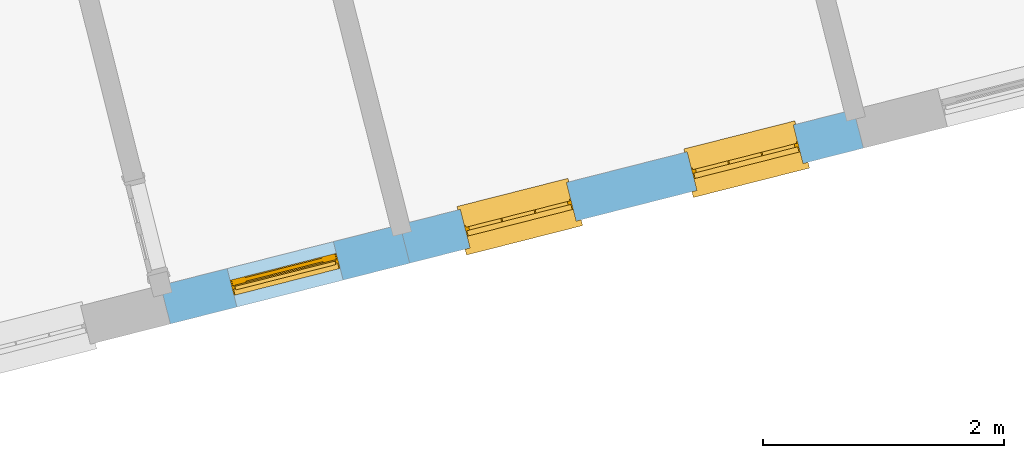
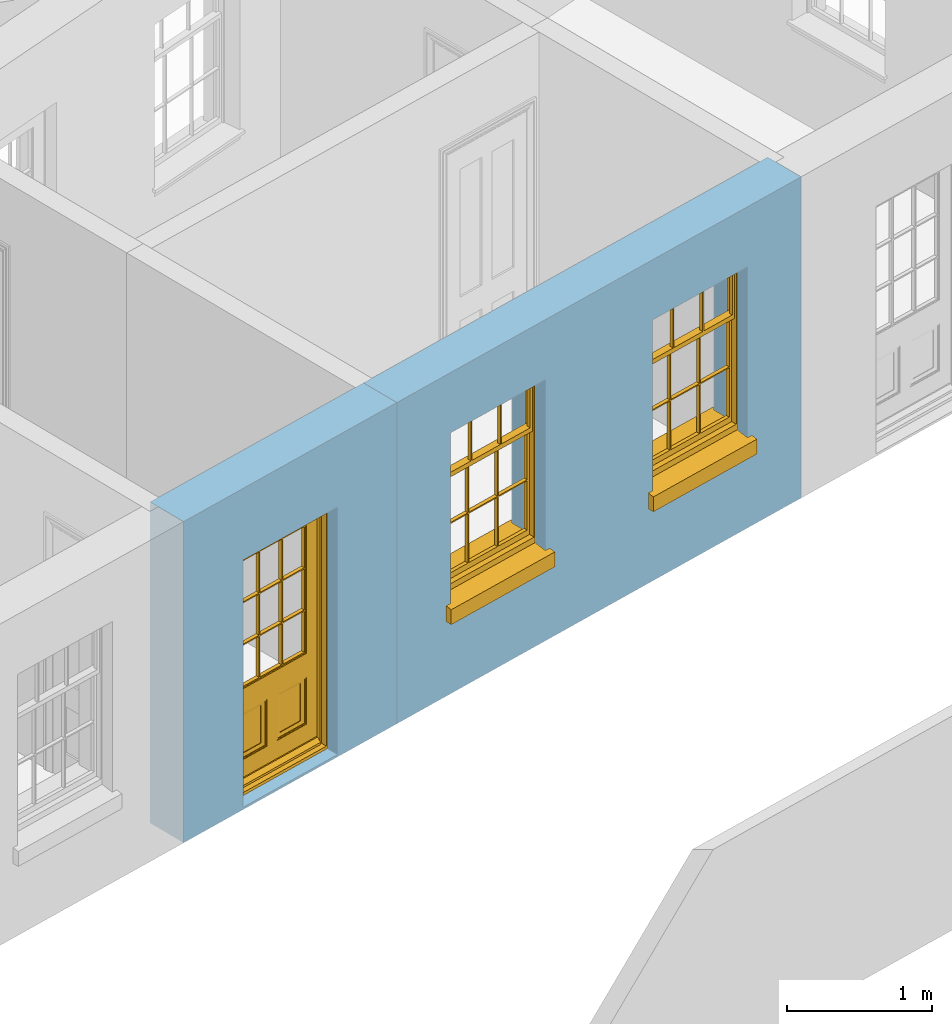
# One storey, part 7 of 15: 2 windows, 1 door, 3 openings, plus 2 elements that do not belong to this part.
"""IFC2X3 building model written with IfcOpenShell, lengths in metres."""

from ifc_helpers import new_model, si_unit, frame, origin, place, context, subcontext, project, spatial, polyline, outline, extrude, faceted_brep, material, layer, layer_set, layer_usage, element, fill, save


model = new_model("IFC2X3")

# Units and contexts
model_context = context("Model", 3, world=origin())
body_context = subcontext(model_context, "Body", "Model", "MODEL_VIEW")
ifc_project = project(units=[si_unit("PLANEANGLEUNIT", "RADIAN"), si_unit("MASSUNIT", "GRAM", prefix="KILO"), si_unit("FORCEUNIT", "NEWTON", prefix="KILO"), si_unit("LENGTHUNIT", "METRE")], contexts=[model_context])

# Site, building, storey
site_placement = place(None, origin())
site = spatial("IfcSite", under=ifc_project, at=site_placement, CompositionType="ELEMENT")
building_placement = place(None, origin())
building = spatial("IfcBuilding", under=site, at=building_placement, Name="Building plot-13", CompositionType="ELEMENT")
storey_placement = place(None, frame((0.0, 0.0, 4.0)))
storey = spatial("IfcBuildingStorey", under=building, at=storey_placement, Name="Floor 0", CompositionType="ELEMENT", Elevation=4.0)

# Wall, opening, door
ifc_material = material(Name="Masonry")
ifc_layer = layer(ifc_material, 0.33, ventilated=False)
ifc_layer_set = layer_set([ifc_layer], Name="My Wall")
ifc_layer_usage = layer_usage(ifc_layer_set, "AXIS2", "NEGATIVE", 0.08)
wall_1_placement = place(storey_placement, origin())
wall_1 = element("IfcWallStandardCase", 1, at=wall_1_placement, inside=storey, material=ifc_layer_usage, Name="exterior", context=body_context, shape_type="SweptSolid", body=[
    extrude(outline(polyline([(71.1697724625834, 45.0137628318924), (71.2509007169492, 44.6938906600119), (73.2374229095042, 45.1977265416814), (73.1562946551384, 45.5175987135619), (71.1697724625834, 45.0137628318924)])), origin(), (0.0, 0.0, 1.0), 2.7),
])
opening_1_placement = place(storey_placement, frame((0.0, 0.0, 0.0199999999999996)))
opening_1 = element("IfcOpeningElement", 2, at=opening_1_placement, cuts=wall_1, Name="Opening", ObjectType="Opening", context=body_context, shape_type="SweptSolid", body=[
    extrude(outline(polyline([(71.8031259398763, 44.8339499470999), (72.6851976865771, 45.0576672545935), (72.6040694322113, 45.377539426474), (71.7219976855105, 45.1538221189804), (71.8031259398763, 44.8339499470999)])), origin(), (0.0, 0.0, 1.0), 2.08),
])
door_placement = place(storey_placement, frame((71.7416651411143, 45.0762773500396, 0.0199999999999996), z_axis=(0.0, 0.0, 1.0), x_axis=(0.882071746700788, 0.223717307493636, 0.0)))
door = element("IfcDoor", 3, at=door_placement, inside=storey, Name="circulation outside door", OverallHeight=2.08, OverallWidth=0.91, context=body_context, shape_type="Brep", held_by="IfcProductRepresentation", body=[
    faceted_brep([(0.545, -0.055, 0.265), (0.745, -0.055, 0.265), (0.745, -0.05, 0.265), (0.545, -0.05, 0.265), (0.745, -0.05, 0.58), (0.545, -0.05, 0.58), (0.545, -0.055, 0.58), (0.515, -0.06, 0.235), (0.775, -0.06, 0.235), (0.745, -0.055, 0.58), (0.515, -0.06, 0.61), (0.515, -0.065, 0.235), (0.775, -0.065, 0.235), (0.775, -0.06, 0.61), (0.515, -0.065, 0.61), (0.785, -0.065, 0.225), (0.505, -0.065, 0.225), (0.775, -0.065, 0.61), (0.505, -0.065, 0.62), (0.785, -0.065, 0.62), (0.505, -0.07, 0.225), (0.785, -0.07, 0.225), (0.505, -0.07, 0.62), (0.785, -0.07, 0.62), (0.883, -0.07, 0.075), (0.898, -0.07, 0.075), (0.405, -0.07, 0.62), (0.405, -0.07, 0.225), (0.027, -0.07, 0.075), (0.785, -0.07, 0.82), (0.125, -0.07, 0.82), (0.405, -0.065, 0.62), (0.405, -0.065, 0.225), (0.898, -0.07, 2.068), (0.027, -0.08, 0.075), (0.883, -0.08, 0.075), (0.125, -0.07, 0.225), (0.012, -0.07, 0.075), (0.785, -0.06, 0.82), (0.125, -0.06, 0.82), (0.125, -0.07, 0.62), (0.125, -0.065, 0.62), (0.395, -0.065, 0.61), (0.395, -0.065, 0.235), (0.125, -0.065, 0.225), (0.785, -0.07, 1.895), (0.027, -0.11, 0.045), (0.883, -0.11, 0.045), (0.558333, -0.06, 0.83), (0.351667, -0.06, 0.83), (0.125, -0.07, 1.895), (0.125, -0.06, 1.895), (0.785, -0.06, 1.895), (0.012, -0.07, 2.068), (0.135, -0.065, 0.61), (0.395, -0.06, 0.61), (0.395, -0.06, 0.235), (0.135, -0.065, 0.235), (0.027, -0.11, 0.027), (0.883, -0.11, 0.027), (0.568333, -0.06, 0.83), (0.558333, -0.03, 0.83), (0.351667, -0.03, 0.83), (0.341667, -0.06, 0.83), (0.135, -0.06, 1.185), (0.135, -0.06, 1.53), (0.775, -0.06, 1.53), (0.775, -0.06, 1.185), (0.135, -0.06, 0.61), (0.365, -0.055, 0.58), (0.365, -0.055, 0.265), (0.135, -0.06, 0.235), (0.568333, -0.06, 1.175), (0.558333, -0.06, 1.175), (0.775, -0.06, 0.83), (0.558333, -0.03, 1.175), (0.785, -0.03, 0.82), (0.125, -0.03, 0.82), (0.351667, -0.03, 1.175), (0.351667, -0.06, 1.175), (0.341667, -0.06, 1.175), (0.135, -0.06, 0.83), (0.135, -0.06, 1.175), (0.135, -0.03, 1.185), (0.135, -0.03, 1.53), (0.135, -0.06, 1.54), (0.351667, -0.06, 1.885), (0.558333, -0.06, 1.885), (0.775, -0.03, 1.53), (0.775, -0.03, 1.185), (0.775, -0.06, 1.175), (0.775, -0.06, 1.54), (0.165, -0.055, 0.58), (0.365, -0.05, 0.58), (0.365, -0.05, 0.265), (0.165, -0.055, 0.265), (0.568333, -0.03, 0.83), (0.568333, -0.03, 1.175), (0.568333, -0.06, 1.185), (0.558333, -0.06, 1.185), (0.775, -0.03, 0.83), (0.785, -0.02, 0.82), (0.125, -0.02, 0.82), (0.341667, -0.03, 0.83), (0.341667, -0.03, 1.175), (0.351667, -0.06, 1.185), (0.341667, -0.06, 1.185), (0.135, -0.03, 0.83), (0.341667, -0.03, 1.185), (0.125, -0.03, 1.895), (0.341667, -0.03, 1.53), (0.341667, -0.06, 1.53), (0.135, -0.06, 1.885), (0.341667, -0.06, 1.54), (0.341667, -0.06, 1.885), (0.558333, -0.03, 1.885), (0.351667, -0.03, 1.885), (0.568333, -0.06, 1.885), (0.785, -0.03, 1.895), (0.568333, -0.03, 1.185), (0.568333, -0.06, 1.53), (0.568333, -0.03, 1.53), (0.568333, -0.06, 1.54), (0.775, -0.06, 1.885), (0.165, -0.05, 0.58), (0.165, -0.05, 0.265), (0.775, -0.03, 1.175), (0.558333, -0.06, 1.53), (0.351667, -0.03, 1.185), (0.558333, -0.03, 1.185), (0.505, -0.02, 0.62), (0.405, -0.02, 0.62), (0.125, -0.02, 1.895), (0.785, -0.02, 1.895), (0.351667, -0.06, 1.53), (0.135, -0.03, 1.175), (0.135, -0.03, 1.54), (0.341667, -0.03, 1.54), (0.135, -0.03, 1.885), (0.351667, -0.06, 1.54), (0.558333, -0.03, 1.54), (0.558333, -0.06, 1.54), (0.351667, -0.03, 1.54), (0.775, -0.03, 1.54), (0.568333, -0.03, 1.54), (0.775, -0.03, 1.885), (0.558333, -0.03, 1.53), (0.405, -0.02, 0.225), (0.505, -0.02, 0.225), (0.125, -0.02, 0.62), (0.785, -0.02, 0.62), (0.012, -0.02, 2.068), (0.898, -0.02, 2.068), (0.351667, -0.03, 1.53), (0.341667, -0.03, 1.885), (0.568333, -0.03, 1.885), (0.405, -0.025, 0.225), (0.405, -0.025, 0.62), (0.505, -0.025, 0.62), (0.505, -0.025, 0.225), (0.898, -0.02, 0.027), (0.012, -0.02, 0.027), (0.125, -0.025, 0.62), (0.785, -0.025, 0.62), (0.395, -0.025, 0.235), (0.395, -0.025, 0.61), (0.125, -0.02, 0.225), (0.125, -0.025, 0.225), (0.515, -0.025, 0.61), (0.515, -0.025, 0.235), (0.785, -0.02, 0.225), (0.785, -0.025, 0.225), (0.135, -0.025, 0.61), (0.775, -0.025, 0.61), (0.135, -0.025, 0.235), (0.395, -0.03, 0.235), (0.395, -0.03, 0.61), (0.515, -0.03, 0.61), (0.515, -0.03, 0.235), (0.775, -0.025, 0.235), (0.135, -0.03, 0.61), (0.775, -0.03, 0.61), (0.135, -0.03, 0.235), (0.365, -0.035, 0.265), (0.365, -0.035, 0.58), (0.545, -0.035, 0.58), (0.545, -0.035, 0.265), (0.775, -0.03, 0.235), (0.165, -0.035, 0.58), (0.745, -0.035, 0.58), (0.165, -0.035, 0.265), (0.365, -0.04, 0.58), (0.365, -0.04, 0.265), (0.545, -0.04, 0.58), (0.545, -0.04, 0.265), (0.745, -0.035, 0.265), (0.165, -0.04, 0.58), (0.745, -0.04, 0.58), (0.165, -0.04, 0.265), (0.745, -0.04, 0.265), (0.885, -0.072, 0.025), (0.025, -0.072, 0.025), (0.025, -0.1, 0.025), (0.885, -0.1, 0.025), (0.9, -0.02, 0.025), (0.01, -0.02, 0.025), (0.9, -0.072, 0.025), (0.91, -0.02, 0.0), (0.0, -0.02, 0.0), (0.01, -0.072, 0.025), (0.9, -0.072, 2.07), (0.9, -0.02, 2.07), (0.885, -0.072, 2.055), (0.91, -0.02, 2.08), (0.01, -0.02, 2.07), (0.0, -0.02, 2.08), (0.01, -0.072, 2.07), (0.025, -0.072, 2.055), (0.0, -0.15, 2.08), (0.91, -0.15, 2.08), (0.01, -0.15, 2.07), (0.9, -0.15, 2.07), (0.01, -0.1, 2.07), (0.9, -0.1, 2.07), (0.0, -0.15, 0.0), (0.91, -0.15, 0.0), (0.01, -0.15, 0.025), (0.9, -0.15, 0.025), (0.01, -0.1, 0.025), (0.025, -0.1, 2.055), (0.9, -0.1, 0.025), (0.885, -0.1, 2.055), (0.898, -0.07, 0.027), (0.012, -0.07, 0.027), (0.883, -0.07, 0.027), (0.027, -0.07, 0.027)], [[[0, 1, 2, 3]], [[2, 4, 5, 3]], [[0, 3, 5, 6]], [[1, 0, 7, 8]], [[9, 4, 2, 1]], [[9, 6, 5, 4]], [[0, 6, 10, 7]], [[8, 7, 11, 12]], [[8, 13, 9, 1]], [[13, 10, 6, 9]], [[7, 10, 14, 11]], [[15, 12, 11, 16]], [[12, 17, 13, 8]], [[17, 14, 10, 13]], [[18, 16, 11, 14]], [[15, 19, 17, 12]], [[15, 16, 20, 21]], [[14, 17, 19, 18]], [[16, 18, 22, 20]], [[21, 23, 19, 15]], [[24, 25, 21, 20]], [[23, 22, 18, 19]], [[20, 22, 26, 27]], [[23, 21, 25]], [[28, 24, 20, 27]], [[22, 23, 29]], [[29, 30, 26, 22]], [[27, 26, 31, 32]], [[23, 25, 33, 29]], [[34, 35, 24, 28]], [[28, 27, 36, 37]], [[38, 39, 30, 29]], [[26, 30, 40]], [[26, 40, 41, 31]], [[42, 43, 32, 31]], [[32, 44, 36, 27]], [[33, 45, 29]], [[46, 47, 35, 34]], [[36, 40, 37]], [[39, 38, 48, 49]], [[50, 30, 39, 51]], [[29, 45, 52, 38]], [[53, 37, 40, 30]], [[44, 41, 40, 36]], [[31, 41, 54, 42]], [[43, 42, 55, 56]], [[57, 44, 32, 43]], [[50, 45, 33, 53]], [[47, 46, 58, 59]], [[60, 48, 38]], [[49, 48, 61, 62]], [[49, 63, 39]], [[50, 53, 30]], [[51, 39, 64, 65]], [[45, 50, 51, 52]], [[66, 67, 38, 52]], [[57, 54, 41, 44]], [[42, 54, 68, 55]], [[56, 55, 69, 70]], [[56, 71, 57, 43]], [[60, 72, 73, 48]], [[60, 38, 74]], [[48, 73, 75, 61]], [[76, 77, 62, 61]], [[62, 78, 79, 49]], [[49, 79, 80, 63]], [[63, 81, 39]], [[82, 64, 39]], [[65, 64, 83, 84]], [[85, 51, 65]], [[52, 51, 86, 87]], [[88, 89, 67, 66]], [[90, 38, 67]], [[91, 66, 52]], [[71, 68, 54, 57]], [[55, 68, 92, 69]], [[69, 93, 94, 70]], [[70, 95, 71, 56]], [[96, 97, 72, 60]], [[73, 72, 98, 99]], [[74, 38, 90]], [[100, 96, 60, 74]], [[75, 73, 79, 78]], [[61, 75, 97, 96]], [[101, 102, 77, 76]], [[77, 103, 62]], [[96, 76, 61]], [[103, 104, 78, 62]], [[80, 79, 105, 106]], [[63, 80, 104, 103]], [[81, 63, 103, 107]], [[81, 82, 39]], [[106, 64, 82, 80]], [[106, 108, 83, 64]], [[84, 83, 77, 109]], [[110, 111, 65, 84]], [[112, 51, 85]], [[113, 85, 65, 111]], [[114, 86, 51]], [[115, 87, 86, 116]], [[117, 52, 87]], [[118, 76, 89, 88]], [[119, 98, 67, 89]], [[120, 121, 88, 66]], [[67, 98, 72, 90]], [[91, 122, 120, 66]], [[91, 52, 123]], [[95, 92, 68, 71]], [[69, 92, 124, 93]], [[94, 93, 124, 125]], [[94, 125, 95, 70]], [[72, 97, 126, 90]], [[127, 99, 98, 120]], [[99, 105, 79, 73]], [[74, 90, 126, 100]], [[96, 100, 76]], [[128, 129, 75, 78]], [[97, 75, 129, 119]], [[130, 131, 102, 101]], [[109, 77, 102, 132]], [[133, 101, 76, 118]], [[77, 107, 103]], [[78, 104, 108, 128]], [[111, 106, 105, 134]], [[104, 80, 82, 135]], [[107, 135, 82, 81]], [[110, 108, 106, 111]], [[104, 135, 83, 108]], [[83, 135, 77]], [[136, 84, 109]], [[110, 84, 136, 137]], [[114, 51, 112]], [[85, 136, 138, 112]], [[113, 137, 136, 85]], [[111, 134, 139, 113]], [[86, 114, 113, 139]], [[140, 141, 87, 115]], [[139, 142, 116, 86]], [[109, 118, 115, 116]], [[117, 123, 52]], [[117, 87, 141, 122]], [[126, 89, 76]], [[143, 118, 88]], [[120, 98, 119, 121]], [[119, 89, 126, 97]], [[144, 143, 88, 121]], [[144, 122, 91, 143]], [[127, 120, 122, 141]], [[143, 91, 123, 145]], [[124, 92, 95, 125]], [[146, 129, 99, 127]], [[99, 129, 128, 105]], [[100, 126, 76]], [[121, 119, 129, 146]], [[147, 131, 130, 148]], [[131, 149, 102]], [[130, 101, 150]], [[102, 151, 132]], [[118, 109, 132, 133]], [[101, 133, 152]], [[107, 77, 135]], [[153, 128, 108, 110]], [[134, 105, 128, 153]], [[109, 138, 136]], [[153, 110, 137, 142]], [[154, 114, 112, 138]], [[137, 113, 114, 154]], [[141, 139, 134, 127]], [[141, 140, 142, 139]], [[144, 140, 115, 155]], [[142, 137, 154, 116]], [[155, 115, 118]], [[116, 154, 109]], [[117, 155, 145, 123]], [[122, 144, 155, 117]], [[143, 145, 118]], [[121, 146, 140, 144]], [[146, 127, 134, 153]], [[156, 157, 131, 147]], [[148, 130, 158, 159]], [[148, 160, 161, 147]], [[157, 162, 149, 131]], [[161, 151, 102, 149]], [[101, 152, 160, 150]], [[163, 158, 130, 150]], [[151, 152, 133, 132]], [[154, 138, 109]], [[142, 140, 146, 153]], [[145, 155, 118]], [[157, 156, 164, 165]], [[147, 166, 167, 156]], [[168, 169, 159, 158]], [[170, 148, 159, 171]], [[148, 170, 160]], [[166, 147, 161]], [[172, 162, 157, 165]], [[166, 149, 162, 167]], [[166, 161, 149]], [[150, 160, 170]], [[163, 173, 168, 158]], [[171, 163, 150, 170]], [[174, 164, 156, 167]], [[175, 176, 165, 164]], [[169, 168, 177, 178]], [[171, 159, 169, 179]], [[167, 162, 172, 174]], [[176, 180, 172, 165]], [[179, 173, 163, 171]], [[181, 177, 168, 173]], [[164, 174, 182, 175]], [[183, 184, 176, 175]], [[178, 177, 185, 186]], [[179, 169, 178, 187]], [[174, 172, 180, 182]], [[184, 188, 180, 176]], [[187, 181, 173, 179]], [[189, 185, 177, 181]], [[175, 182, 190, 183]], [[191, 184, 183, 192]], [[185, 193, 194, 186]], [[187, 178, 186, 195]], [[182, 180, 188, 190]], [[191, 196, 188, 184]], [[195, 189, 181, 187]], [[197, 193, 185, 189]], [[183, 190, 198, 192]], [[198, 196, 191, 192]], [[194, 193, 197, 199]], [[195, 186, 194, 199]], [[188, 196, 198, 190]], [[197, 189, 195, 199]], [[200, 201, 202, 203]], [[201, 200, 204, 205]], [[206, 204, 200]], [[204, 207, 208, 205]], [[209, 201, 205]], [[210, 211, 204, 206]], [[206, 200, 212, 210]], [[211, 213, 207, 204]], [[214, 205, 208, 215]], [[216, 217, 201, 209]], [[205, 214, 216, 209]], [[216, 214, 211, 210]], [[210, 212, 217, 216]], [[214, 215, 213, 211]], [[218, 219, 213, 215]], [[219, 218, 220, 221]], [[221, 220, 222, 223]], [[215, 208, 224, 218]], [[225, 224, 208, 207]], [[224, 226, 220, 218]], [[224, 225, 227, 226]], [[219, 225, 207, 213]], [[228, 222, 220, 226]], [[219, 221, 227, 225]], [[226, 227, 203, 202]], [[202, 229, 222, 228]], [[228, 226, 202]], [[227, 221, 223, 230]], [[230, 203, 227]], [[217, 229, 202, 201]], [[231, 223, 222, 229]], [[230, 223, 231, 203]], [[231, 229, 217, 212]], [[212, 200, 203, 231]], [[33, 152, 151, 53]], [[25, 160, 152, 33]], [[161, 37, 53, 151]], [[232, 160, 25]], [[161, 233, 37]], [[160, 232, 234]], [[24, 234, 232, 25]], [[233, 161, 235]], [[37, 233, 235, 28]], [[161, 160, 234, 235]], [[35, 47, 234, 24]], [[28, 235, 46, 34]], [[58, 235, 234, 59]], [[59, 234, 47]], [[58, 46, 235]]]),
])
fill(opening_1, door)

# Wall, openings, windows
wall_2_placement = place(storey_placement, origin())
wall_2 = element("IfcWallStandardCase", 4, at=wall_2_placement, inside=storey, material=ifc_layer_usage, Name="exterior", context=body_context, shape_type="SweptSolid", body=[
    extrude(outline(polyline([(73.1562946551384, 45.5175987135619), (73.2374229095042, 45.1977265416814), (77.0032448604169, 46.1528410780099), (76.9221166060511, 46.4727132498904), (73.1562946551384, 45.5175987135619)])), origin(), (0.0, 0.0, 1.0), 2.7),
])
opening_2_placement = place(storey_placement, frame((0.0, 0.0, 0.75)))
opening_2 = element("IfcOpeningElement", 5, at=opening_2_placement, cuts=wall_2, Name="Opening", ObjectType="Opening", context=body_context, shape_type="SweptSolid", body=[
    extrude(outline(polyline([(73.737842523882, 45.3246465220167), (74.6199142705828, 45.5483638295104), (74.5387860162169, 45.8682360013909), (73.6567142695161, 45.6445186938972), (73.737842523882, 45.3246465220167)])), origin(), (0.0, 0.0, 1.0), 1.445),
])
opening_3_placement = place(storey_placement, frame((0.0, 0.0, 0.75)))
opening_3 = element("IfcOpeningElement", 6, at=opening_3_placement, cuts=wall_2, Name="Opening", ObjectType="Opening", context=body_context, shape_type="SweptSolid", body=[
    extrude(outline(polyline([(75.6207534993383, 45.802203790181), (76.5028252460391, 46.0259210976746), (76.4216969916733, 46.3457932695551), (75.5396252449725, 46.1220759620615), (75.6207534993383, 45.802203790181)])), origin(), (0.0, 0.0, 1.0), 1.445),
])
window_1_placement = place(storey_placement, frame((73.67638172512, 45.5669739249565, 0.75), z_axis=(0.0, 0.0, 1.0), x_axis=(0.882071746700802, 0.223717307493629, 0.0)))
window_1 = element("IfcWindow", 7, at=window_1_placement, inside=storey, Name="toilet outside window", OverallHeight=1.445, OverallWidth=0.91, context=body_context, shape_type="Brep", held_by="IfcProductRepresentation", body=[
    faceted_brep([(0.876875, -0.105, 0.999097), (0.876875, -0.105, 1.411875), (0.9, -0.105, 1.435), (0.033125, -0.105, 1.411875), (0.033125, -0.105, 0.999097), (0.01, -0.105, 1.435), (0.033125, -0.135, 1.411875), (0.01, -0.135, 1.435), (0.033125, -0.135, 0.999097), (0.876875, -0.135, 1.411875), (0.876875, -0.135, 0.999097), (0.9, -0.135, 1.435), (0.033125, -0.105, 0.960972), (0.01, -0.105, 0.960972), (0.033125, -0.105, 0.548195), (0.876875, -0.105, 0.960972), (0.876875, -0.105, 0.548195), (0.9, -0.105, 0.960972), (0.876875, -0.105, 0.538195), (0.876875, -0.105, 0.125417), (0.9, -0.105, 0.077167), (0.033125, -0.105, 0.125417), (0.033125, -0.105, 0.538195), (0.01, -0.105, 0.077167), (0.9, -0.135, 0.960972), (0.01, -0.135, 0.960972), (-0.0425, -0.25, 0.01), (-0.0425, -0.3, 0.001667), (0.0, -0.25, 0.01), (0.9525, -0.25, 0.01), (0.91, -0.25, 0.01), (0.9525, -0.3, 0.001667), (-0.02, 0.08, 0.077167), (0.0, 0.08, 0.077167), (-0.02, 0.11, 0.077167), (0.0, -0.06, 0.077167), (0.01, -0.06, 0.077167), (0.91, -0.06, 0.077167), (0.91, 0.08, 0.077167), (0.9, -0.06, 0.077167), (0.93, 0.08, 0.077167), (0.93, 0.11, 0.077167), (0.01, -0.105, 0.999097), (0.01, -0.075, 0.999097), (0.9, -0.105, 0.999097), (0.9, -0.075, 0.999097), (0.876875, -0.075, 0.125417), (0.876875, -0.075, 0.538195), (0.9, -0.075, 0.077167), (0.876875, -0.075, 0.548195), (0.876875, -0.075, 0.960972), (0.033125, -0.075, 0.125417), (0.01, -0.075, 0.077167), (0.033125, -0.075, 0.538195), (0.033125, -0.075, 0.960972), (0.033125, -0.075, 0.548195), (-0.02, 0.08, 0.052167), (-0.02, 0.11, 0.052167), (0.93, 0.11, 0.052167), (0.93, 0.08, 0.052167), (0.91, 0.08, 0.052167), (0.0, 0.08, 0.052167), (0.91, -0.15, 0.026667), (0.0, -0.15, 0.026667), (-0.0425, -0.3, -0.123333), (0.9525, -0.3, -0.123333), (-0.0425, -0.25, -0.123333), (0.9525, -0.25, -0.123333), (0.01, -0.06, 1.435), (0.9, -0.06, 1.435), (0.0, -0.06, 1.445), (0.91, -0.06, 1.445), (0.01, -0.15, 0.077167), (0.9, -0.15, 0.077167), (0.592292, -0.105, 0.125417), (0.592292, -0.075, 0.125417), (0.317708, -0.075, 0.125417), (0.317708, -0.105, 0.125417), (0.592292, -0.105, 0.548195), (0.317708, -0.105, 0.548195), (0.317708, -0.105, 0.538195), (0.592292, -0.105, 0.538195), (0.592292, -0.075, 0.548195), (0.317708, -0.075, 0.548195), (0.602292, -0.075, 0.548195), (0.602292, -0.105, 0.548195), (0.317708, -0.075, 0.538195), (0.307708, -0.075, 0.125417), (0.307708, -0.075, 0.538195), (0.602292, -0.075, 0.538195), (0.602292, -0.075, 0.125417), (0.592292, -0.075, 0.538195), (0.307708, -0.075, 0.548195), (0.317708, -0.075, 0.960972), (0.307708, -0.075, 0.960972), (0.602292, -0.075, 0.960972), (0.592292, -0.075, 0.960972), (0.307708, -0.105, 0.538195), (0.307708, -0.105, 0.125417), (0.307708, -0.105, 0.548195), (0.307708, -0.105, 0.960972), (0.592292, -0.105, 0.960972), (0.317708, -0.105, 0.960972), (0.602292, -0.105, 0.960972), (0.602292, -0.105, 0.538195), (0.602292, -0.105, 0.125417), (0.317708, -0.135, 1.411875), (0.307708, -0.135, 1.411875), (0.307708, -0.135, 0.999097), (0.317708, -0.135, 0.999097), (0.602292, -0.135, 1.411875), (0.592292, -0.135, 1.411875), (0.592292, -0.135, 0.999097), (0.602292, -0.135, 0.999097), (0.317708, -0.105, 0.999097), (0.307708, -0.105, 0.999097), (0.307708, -0.105, 1.411875), (0.317708, -0.105, 1.411875), (0.602292, -0.105, 0.999097), (0.592292, -0.105, 0.999097), (0.592292, -0.105, 1.411875), (0.602292, -0.105, 1.411875), (0.91, -0.15, 1.445), (0.9, -0.15, 1.435), (0.01, -0.15, 1.435), (0.0, -0.15, 1.445), (0.91, -0.25, 0.0), (0.0, -0.25, 0.0), (0.91, 0.08, 0.0), (0.0, 0.08, 0.0)], [[[0, 1, 2]], [[3, 4, 5]], [[6, 7, 8]], [[9, 10, 11]], [[12, 13, 14]], [[15, 16, 17]], [[18, 19, 20]], [[21, 22, 23]], [[24, 15, 17]], [[13, 12, 25]], [[26, 27, 28]], [[29, 30, 31]], [[32, 33, 34]], [[35, 36, 33]], [[37, 38, 39]], [[40, 41, 38]], [[42, 4, 43]], [[44, 45, 0]], [[46, 47, 48]], [[49, 50, 45]], [[51, 52, 53]], [[54, 55, 43]], [[38, 33, 36, 39]], [[41, 34, 33, 38]], [[56, 32, 34, 57]], [[57, 34, 41, 58]], [[58, 41, 40, 59]], [[57, 58, 60, 61]], [[52, 48, 39, 36]], [[62, 63, 28, 30]], [[27, 31, 30, 28]], [[27, 64, 65, 31]], [[66, 67, 65, 64]], [[2, 5, 68, 69]], [[68, 70, 71, 69]], [[20, 23, 72, 73]], [[73, 72, 63, 62]], [[74, 75, 76, 77]], [[78, 79, 80, 81]], [[78, 82, 83, 79]], [[16, 49, 84, 85]], [[86, 76, 87, 88]], [[89, 90, 75, 91]], [[92, 88, 53, 55]], [[82, 91, 86, 83]], [[93, 83, 92, 94]], [[95, 84, 82, 96]], [[89, 84, 49, 47]], [[97, 88, 87, 98]], [[22, 53, 88, 97]], [[81, 91, 75, 74]], [[80, 86, 91, 81]], [[77, 76, 86, 80]], [[99, 92, 55, 14]], [[100, 94, 92, 99]], [[101, 96, 82, 78]], [[79, 83, 93, 102]], [[85, 84, 95, 103]], [[104, 89, 47, 18]], [[105, 90, 89, 104]], [[104, 18, 16, 85]], [[80, 97, 98, 77]], [[104, 81, 74, 105]], [[103, 101, 78, 85]], [[99, 14, 22, 97]], [[102, 100, 99, 79]], [[106, 107, 108, 109]], [[110, 111, 112, 113]], [[114, 115, 116, 117]], [[118, 119, 120, 121]], [[107, 116, 115, 108]], [[111, 120, 119, 112]], [[109, 114, 117, 106]], [[113, 118, 121, 110]], [[85, 78, 81, 104]], [[84, 89, 91, 82]], [[83, 86, 88, 92]], [[79, 99, 97, 80]], [[109, 112, 119, 114]], [[102, 93, 96, 101]], [[106, 117, 120, 111]], [[98, 87, 51, 21]], [[6, 3, 116, 107]], [[110, 121, 1, 9]], [[19, 46, 90, 105]], [[26, 66, 64, 27]], [[29, 31, 65, 67]], [[25, 24, 112, 109]], [[11, 7, 106, 111]], [[75, 48, 52, 76]], [[43, 45, 96, 93]], [[45, 43, 114, 119]], [[5, 2, 120, 117]], [[24, 25, 102, 101]], [[42, 5, 4]], [[2, 44, 0]], [[49, 45, 48, 47]], [[52, 43, 55, 53]], [[14, 13, 23, 22]], [[20, 17, 16, 18]], [[24, 11, 10]], [[25, 8, 7]], [[8, 4, 3, 6]], [[9, 1, 0, 10]], [[15, 50, 49, 16]], [[18, 47, 46, 19]], [[21, 51, 53, 22]], [[14, 55, 54, 12]], [[44, 2, 69, 45]], [[68, 5, 42, 43]], [[36, 35, 70, 68]], [[39, 69, 71, 37]], [[62, 122, 123, 73]], [[63, 72, 124, 125]], [[8, 108, 115, 4]], [[113, 10, 0, 118]], [[94, 100, 12, 54]], [[17, 20, 73, 24]], [[72, 23, 13, 25]], [[52, 36, 68, 43]], [[69, 39, 48, 45]], [[11, 24, 73, 123]], [[7, 124, 72, 25]], [[23, 77, 98]], [[98, 21, 23]], [[105, 74, 20]], [[20, 19, 105]], [[20, 74, 77, 23]], [[113, 112, 24]], [[24, 10, 113]], [[25, 109, 108]], [[108, 8, 25]], [[110, 9, 11]], [[11, 111, 110]], [[7, 6, 107]], [[107, 106, 7]], [[5, 117, 116]], [[116, 3, 5]], [[121, 120, 2]], [[2, 1, 121]], [[11, 123, 124, 7]], [[122, 125, 124, 123]], [[43, 93, 94]], [[94, 54, 43]], [[96, 45, 95]], [[50, 95, 45]], [[15, 103, 95, 50]], [[48, 75, 90]], [[90, 46, 48]], [[87, 76, 52]], [[52, 51, 87]], [[103, 15, 24]], [[24, 101, 103]], [[100, 102, 25]], [[25, 12, 100]], [[115, 114, 43]], [[43, 4, 115]], [[118, 0, 45]], [[45, 119, 118]], [[71, 70, 125, 122]], [[70, 35, 63, 125]], [[122, 62, 37, 71]], [[126, 67, 66, 127]], [[60, 58, 59]], [[38, 60, 59, 40]], [[61, 56, 57]], [[32, 56, 61, 33]], [[61, 60, 128, 129]], [[62, 60, 38, 37]], [[126, 128, 60, 62]], [[33, 61, 63, 35]], [[61, 129, 127, 63]], [[128, 126, 127, 129]], [[28, 127, 66, 26]], [[63, 127, 28]], [[29, 67, 126, 30]], [[30, 126, 62]]]),
])
fill(opening_2, window_1)
window_2_placement = place(storey_placement, frame((75.5592927005763, 46.0445311931208, 0.75), z_axis=(0.0, 0.0, 1.0), x_axis=(0.882071746700802, 0.223717307493629, 0.0)))
window_2 = element("IfcWindow", 8, at=window_2_placement, inside=storey, Name="toilet outside window", OverallHeight=1.445, OverallWidth=0.91, context=body_context, shape_type="Brep", held_by="IfcProductRepresentation", body=[
    faceted_brep([(0.876875, -0.105, 0.999097), (0.876875, -0.105, 1.411875), (0.9, -0.105, 1.435), (0.033125, -0.105, 1.411875), (0.033125, -0.105, 0.999097), (0.01, -0.105, 1.435), (0.033125, -0.135, 1.411875), (0.01, -0.135, 1.435), (0.033125, -0.135, 0.999097), (0.876875, -0.135, 1.411875), (0.876875, -0.135, 0.999097), (0.9, -0.135, 1.435), (0.033125, -0.105, 0.960972), (0.01, -0.105, 0.960972), (0.033125, -0.105, 0.548195), (0.876875, -0.105, 0.960972), (0.876875, -0.105, 0.548195), (0.9, -0.105, 0.960972), (0.876875, -0.105, 0.538195), (0.876875, -0.105, 0.125417), (0.9, -0.105, 0.077167), (0.033125, -0.105, 0.125417), (0.033125, -0.105, 0.538195), (0.01, -0.105, 0.077167), (0.9, -0.135, 0.960972), (0.01, -0.135, 0.960972), (-0.0425, -0.25, 0.01), (-0.0425, -0.3, 0.001667), (0.0, -0.25, 0.01), (0.9525, -0.25, 0.01), (0.91, -0.25, 0.01), (0.9525, -0.3, 0.001667), (-0.02, 0.08, 0.077167), (0.0, 0.08, 0.077167), (-0.02, 0.11, 0.077167), (0.0, -0.06, 0.077167), (0.01, -0.06, 0.077167), (0.91, -0.06, 0.077167), (0.91, 0.08, 0.077167), (0.9, -0.06, 0.077167), (0.93, 0.08, 0.077167), (0.93, 0.11, 0.077167), (0.01, -0.105, 0.999097), (0.01, -0.075, 0.999097), (0.9, -0.105, 0.999097), (0.9, -0.075, 0.999097), (0.876875, -0.075, 0.125417), (0.876875, -0.075, 0.538195), (0.9, -0.075, 0.077167), (0.876875, -0.075, 0.548195), (0.876875, -0.075, 0.960972), (0.033125, -0.075, 0.125417), (0.01, -0.075, 0.077167), (0.033125, -0.075, 0.538195), (0.033125, -0.075, 0.960972), (0.033125, -0.075, 0.548195), (-0.02, 0.08, 0.052167), (-0.02, 0.11, 0.052167), (0.93, 0.11, 0.052167), (0.93, 0.08, 0.052167), (0.91, 0.08, 0.052167), (0.0, 0.08, 0.052167), (0.91, -0.15, 0.026667), (0.0, -0.15, 0.026667), (-0.0425, -0.3, -0.123333), (0.9525, -0.3, -0.123333), (-0.0425, -0.25, -0.123333), (0.9525, -0.25, -0.123333), (0.01, -0.06, 1.435), (0.9, -0.06, 1.435), (0.0, -0.06, 1.445), (0.91, -0.06, 1.445), (0.01, -0.15, 0.077167), (0.9, -0.15, 0.077167), (0.592292, -0.105, 0.125417), (0.592292, -0.075, 0.125417), (0.317708, -0.075, 0.125417), (0.317708, -0.105, 0.125417), (0.592292, -0.105, 0.548195), (0.317708, -0.105, 0.548195), (0.317708, -0.105, 0.538195), (0.592292, -0.105, 0.538195), (0.592292, -0.075, 0.548195), (0.317708, -0.075, 0.548195), (0.602292, -0.075, 0.548195), (0.602292, -0.105, 0.548195), (0.317708, -0.075, 0.538195), (0.307708, -0.075, 0.125417), (0.307708, -0.075, 0.538195), (0.602292, -0.075, 0.538195), (0.602292, -0.075, 0.125417), (0.592292, -0.075, 0.538195), (0.307708, -0.075, 0.548195), (0.317708, -0.075, 0.960972), (0.307708, -0.075, 0.960972), (0.602292, -0.075, 0.960972), (0.592292, -0.075, 0.960972), (0.307708, -0.105, 0.538195), (0.307708, -0.105, 0.125417), (0.307708, -0.105, 0.548195), (0.307708, -0.105, 0.960972), (0.592292, -0.105, 0.960972), (0.317708, -0.105, 0.960972), (0.602292, -0.105, 0.960972), (0.602292, -0.105, 0.538195), (0.602292, -0.105, 0.125417), (0.317708, -0.135, 1.411875), (0.307708, -0.135, 1.411875), (0.307708, -0.135, 0.999097), (0.317708, -0.135, 0.999097), (0.602292, -0.135, 1.411875), (0.592292, -0.135, 1.411875), (0.592292, -0.135, 0.999097), (0.602292, -0.135, 0.999097), (0.317708, -0.105, 0.999097), (0.307708, -0.105, 0.999097), (0.307708, -0.105, 1.411875), (0.317708, -0.105, 1.411875), (0.602292, -0.105, 0.999097), (0.592292, -0.105, 0.999097), (0.592292, -0.105, 1.411875), (0.602292, -0.105, 1.411875), (0.91, -0.15, 1.445), (0.9, -0.15, 1.435), (0.01, -0.15, 1.435), (0.0, -0.15, 1.445), (0.91, -0.25, 0.0), (0.0, -0.25, 0.0), (0.91, 0.08, 0.0), (0.0, 0.08, 0.0)], [[[0, 1, 2]], [[3, 4, 5]], [[6, 7, 8]], [[9, 10, 11]], [[12, 13, 14]], [[15, 16, 17]], [[18, 19, 20]], [[21, 22, 23]], [[24, 15, 17]], [[13, 12, 25]], [[26, 27, 28]], [[29, 30, 31]], [[32, 33, 34]], [[35, 36, 33]], [[37, 38, 39]], [[40, 41, 38]], [[42, 4, 43]], [[44, 45, 0]], [[46, 47, 48]], [[49, 50, 45]], [[51, 52, 53]], [[54, 55, 43]], [[38, 33, 36, 39]], [[41, 34, 33, 38]], [[56, 32, 34, 57]], [[57, 34, 41, 58]], [[58, 41, 40, 59]], [[57, 58, 60, 61]], [[52, 48, 39, 36]], [[62, 63, 28, 30]], [[27, 31, 30, 28]], [[27, 64, 65, 31]], [[66, 67, 65, 64]], [[2, 5, 68, 69]], [[68, 70, 71, 69]], [[20, 23, 72, 73]], [[73, 72, 63, 62]], [[74, 75, 76, 77]], [[78, 79, 80, 81]], [[78, 82, 83, 79]], [[16, 49, 84, 85]], [[86, 76, 87, 88]], [[89, 90, 75, 91]], [[92, 88, 53, 55]], [[82, 91, 86, 83]], [[93, 83, 92, 94]], [[95, 84, 82, 96]], [[89, 84, 49, 47]], [[97, 88, 87, 98]], [[22, 53, 88, 97]], [[81, 91, 75, 74]], [[80, 86, 91, 81]], [[77, 76, 86, 80]], [[99, 92, 55, 14]], [[100, 94, 92, 99]], [[101, 96, 82, 78]], [[79, 83, 93, 102]], [[85, 84, 95, 103]], [[104, 89, 47, 18]], [[105, 90, 89, 104]], [[104, 18, 16, 85]], [[80, 97, 98, 77]], [[104, 81, 74, 105]], [[103, 101, 78, 85]], [[99, 14, 22, 97]], [[102, 100, 99, 79]], [[106, 107, 108, 109]], [[110, 111, 112, 113]], [[114, 115, 116, 117]], [[118, 119, 120, 121]], [[107, 116, 115, 108]], [[111, 120, 119, 112]], [[109, 114, 117, 106]], [[113, 118, 121, 110]], [[85, 78, 81, 104]], [[84, 89, 91, 82]], [[83, 86, 88, 92]], [[79, 99, 97, 80]], [[109, 112, 119, 114]], [[102, 93, 96, 101]], [[106, 117, 120, 111]], [[98, 87, 51, 21]], [[6, 3, 116, 107]], [[110, 121, 1, 9]], [[19, 46, 90, 105]], [[26, 66, 64, 27]], [[29, 31, 65, 67]], [[25, 24, 112, 109]], [[11, 7, 106, 111]], [[75, 48, 52, 76]], [[43, 45, 96, 93]], [[45, 43, 114, 119]], [[5, 2, 120, 117]], [[24, 25, 102, 101]], [[42, 5, 4]], [[2, 44, 0]], [[49, 45, 48, 47]], [[52, 43, 55, 53]], [[14, 13, 23, 22]], [[20, 17, 16, 18]], [[24, 11, 10]], [[25, 8, 7]], [[8, 4, 3, 6]], [[9, 1, 0, 10]], [[15, 50, 49, 16]], [[18, 47, 46, 19]], [[21, 51, 53, 22]], [[14, 55, 54, 12]], [[44, 2, 69, 45]], [[68, 5, 42, 43]], [[36, 35, 70, 68]], [[39, 69, 71, 37]], [[62, 122, 123, 73]], [[63, 72, 124, 125]], [[8, 108, 115, 4]], [[113, 10, 0, 118]], [[94, 100, 12, 54]], [[17, 20, 73, 24]], [[72, 23, 13, 25]], [[52, 36, 68, 43]], [[69, 39, 48, 45]], [[11, 24, 73, 123]], [[7, 124, 72, 25]], [[23, 77, 98]], [[98, 21, 23]], [[105, 74, 20]], [[20, 19, 105]], [[20, 74, 77, 23]], [[113, 112, 24]], [[24, 10, 113]], [[25, 109, 108]], [[108, 8, 25]], [[110, 9, 11]], [[11, 111, 110]], [[7, 6, 107]], [[107, 106, 7]], [[5, 117, 116]], [[116, 3, 5]], [[121, 120, 2]], [[2, 1, 121]], [[11, 123, 124, 7]], [[122, 125, 124, 123]], [[43, 93, 94]], [[94, 54, 43]], [[96, 45, 95]], [[50, 95, 45]], [[15, 103, 95, 50]], [[48, 75, 90]], [[90, 46, 48]], [[87, 76, 52]], [[52, 51, 87]], [[103, 15, 24]], [[24, 101, 103]], [[100, 102, 25]], [[25, 12, 100]], [[115, 114, 43]], [[43, 4, 115]], [[118, 0, 45]], [[45, 119, 118]], [[71, 70, 125, 122]], [[70, 35, 63, 125]], [[122, 62, 37, 71]], [[126, 67, 66, 127]], [[60, 58, 59]], [[38, 60, 59, 40]], [[61, 56, 57]], [[32, 56, 61, 33]], [[61, 60, 128, 129]], [[62, 60, 38, 37]], [[126, 128, 60, 62]], [[33, 61, 63, 35]], [[61, 129, 127, 63]], [[128, 126, 127, 129]], [[28, 127, 66, 26]], [[63, 127, 28]], [[29, 67, 126, 30]], [[30, 126, 62]]]),
])
fill(opening_3, window_2)

save(model, "model.ifc")
